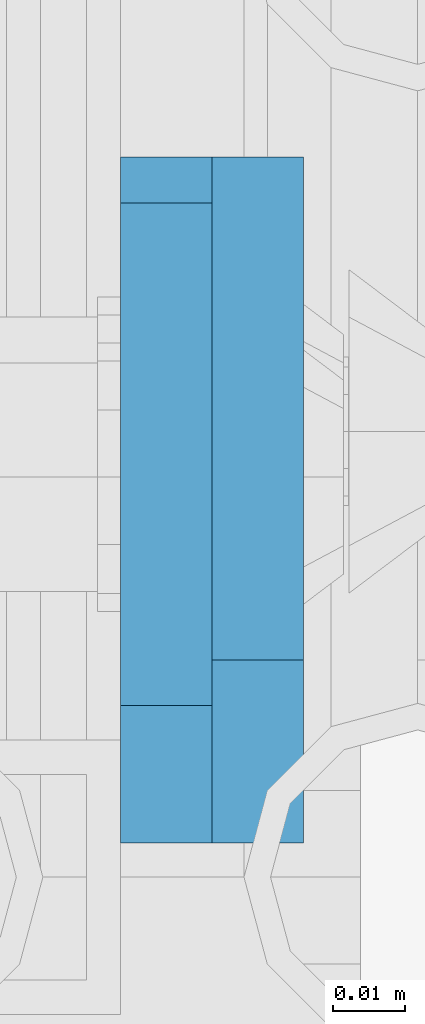
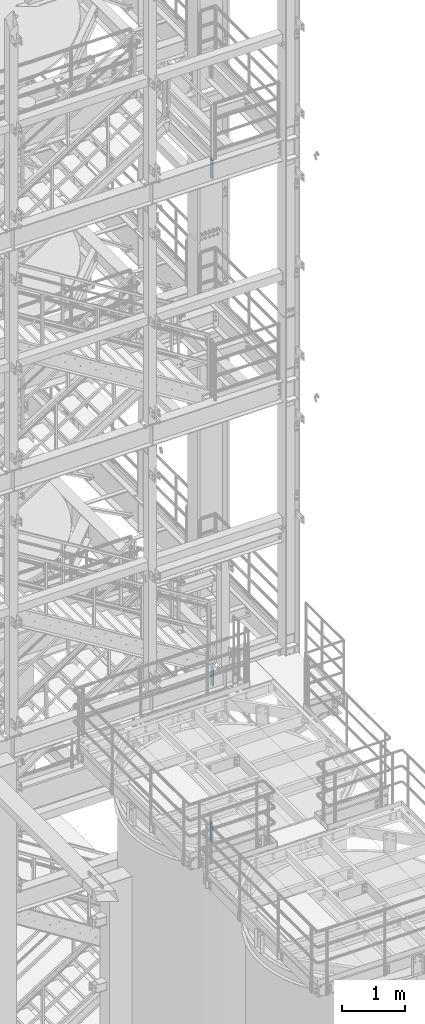
# One storey, part 1453 of 1876: 3 plates, 3 elements without a shape of their own.
"""IFC2X3 building model written with IfcOpenShell, lengths in millimetres."""

from ifc_helpers import new_model, si_unit, frame, origin_with_axes, place, context, subcontext, project, spatial, faceted_brep, material, type_object, element, aggregate, save


model = new_model("IFC2X3")

# Units and contexts
model_context = context("Model", 3, precision=1e-05, world=origin_with_axes())
body_context = subcontext(model_context, "Body", "Model", "MODEL_VIEW")
ifc_project = project(units=[si_unit("LENGTHUNIT", "METRE", prefix="MILLI"), si_unit("AREAUNIT", "SQUARE_METRE"), si_unit("VOLUMEUNIT", "CUBIC_METRE"), si_unit("MASSUNIT", "GRAM", prefix="KILO"), si_unit("TIMEUNIT", "SECOND"), si_unit("PLANEANGLEUNIT", "RADIAN"), si_unit("SOLIDANGLEUNIT", "STERADIAN"), si_unit("THERMODYNAMICTEMPERATUREUNIT", "DEGREE_CELSIUS"), si_unit("LUMINOUSINTENSITYUNIT", "LUMEN")], contexts=[model_context])

# Site, building, storey
site_placement = place(None, origin_with_axes())
site = spatial("IfcSite", under=ifc_project, at=site_placement, CompositionType="ELEMENT")
building_placement = place(site_placement, origin_with_axes())
building = spatial("IfcBuilding", under=site, at=building_placement, Name="Undefined", CompositionType="ELEMENT")
storey_placement = place(building_placement, origin_with_axes())
storey = spatial("IfcBuildingStorey", under=building, at=storey_placement, Name="Undefined", CompositionType="ELEMENT", Elevation=0.0)

# Assembly, plate
assembly_1_placement = place(storey_placement, origin_with_axes())
assembly_1 = element("IfcElementAssembly", 1, at=assembly_1_placement, inside=storey, Name="BEAM", AssemblyPlace="NOTDEFINED", PredefinedType="RIGID_FRAME")
ifc_material = material(Name="STEEL/A36")
plate_type_1 = type_object("IfcPlateType", PredefinedType="NOTDEFINED")
plate_1_placement = place(assembly_1_placement, frame((6238.87499990463, -7107.2375, 17587.9125), z_axis=(0.0, 0.0, 1.0), x_axis=(0.0, 1.0, 0.0)))
plate_1 = element("IfcPlate", 2, at=plate_1_placement, type_object=plate_type_1, material=ifc_material, Name="PLATE", context=body_context, shape_type="Brep", body=[
    faceted_brep([(0.0, -6.35000000000196, 19.0499992370605), (0.0, -6.35000000000036, 361.950000762939), (0.0, 6.35000000000036, 361.950000762939), (0.0, 6.35000000000105, 19.0499992370605), (19.0499992370605, -6.35000000000036, 381.0), (19.0499992370605, 6.35000000000036, 381.0), (88.9000015258789, -6.35000000000036, 381.0), (88.9000015258789, 6.35000000000036, 381.0), (88.9000015258789, -6.34999999999991, 0.0), (88.9000015258789, 6.34999999999991, 0.0), (19.0499992370642, -6.35000000000105, 0.0), (19.0499992370633, 6.35000000000105, 0.0)], [[[0, 1, 2, 3]], [[1, 4, 5, 2]], [[4, 6, 7, 5]], [[6, 8, 9, 7]], [[8, 10, 11, 9]], [[10, 0, 3, 11]], [[5, 7, 9, 11, 3, 2]], [[10, 8, 6, 4, 1, 0]]]),
])
aggregate(assembly_1, [plate_1])

assembly_2_placement = place(storey_placement, origin_with_axes())
assembly_2 = element("IfcElementAssembly", 3, at=assembly_2_placement, inside=storey, Name="BEAM", AssemblyPlace="NOTDEFINED", PredefinedType="RIGID_FRAME")
plate_type_2 = type_object("IfcPlateType", PredefinedType="NOTDEFINED")
plate_2_placement = place(assembly_2_placement, frame((6251.57499990463, -7107.2375, 7759.7), z_axis=(0.0, 0.0, 1.0), x_axis=(0.0, 1.0, 0.0)))
plate_2 = element("IfcPlate", 4, at=plate_2_placement, type_object=plate_type_2, material=ifc_material, Name="PLATE", context=body_context, shape_type="Brep", body=[
    faceted_brep([(0.0, -6.35000000000036, 25.4000000000005), (0.0, -6.35000000000036, 354.012506484985), (0.0, 6.35000000000036, 354.012506484985), (0.0, 6.35000000000036, 25.4000000000005), (25.3999996185303, -6.35000000000036, 379.412506103516), (25.3999996185303, 6.35000000000036, 379.412506103516), (95.25, -6.35000000000036, 379.412506103516), (95.25, 6.35000000000036, 379.412506103516), (95.25, -6.35000000000036, 0.0), (95.25, 6.35000000000036, 0.0), (25.3999996185303, -6.34999999999991, 0.0), (25.3999996185303, 6.34999999999991, 0.0)], [[[0, 1, 2, 3]], [[1, 4, 5, 2]], [[4, 6, 7, 5]], [[6, 8, 9, 7]], [[8, 10, 11, 9]], [[10, 0, 3, 11]], [[5, 7, 9, 11, 3, 2]], [[10, 8, 6, 4, 1, 0]]]),
])
aggregate(assembly_2, [plate_2])

assembly_3_placement = place(storey_placement, origin_with_axes())
assembly_3 = element("IfcElementAssembly", 5, at=assembly_3_placement, inside=storey, Name="BEAM", AssemblyPlace="NOTDEFINED", PredefinedType="RIGID_FRAME")
plate_3_placement = place(assembly_3_placement, frame((6238.875, -7107.2375, 4737.1), z_axis=(0.0, 0.0, 1.0), x_axis=(0.0, 1.0, 0.0)))
plate_3 = element("IfcPlate", 6, at=plate_3_placement, type_object=plate_type_2, material=ifc_material, Name="PLATE", context=body_context, shape_type="Brep", body=[
    faceted_brep([(0.0, -6.35000000000036, 25.4000000000005), (0.0, -6.35000000000036, 354.012506484985), (0.0, 6.35000000000036, 354.012506484985), (0.0, 6.35000000000036, 25.4000000000005), (25.3999996185303, -6.35000000000036, 379.412506103516), (25.3999996185303, 6.35000000000036, 379.412506103516), (95.25, -6.35000000000036, 379.412506103516), (95.25, 6.35000000000036, 379.412506103516), (95.25, -6.35000000000036, 0.0), (95.25, 6.35000000000036, 0.0), (25.3999996185303, -6.34999999999991, 0.0), (25.3999996185303, 6.34999999999991, 0.0)], [[[0, 1, 2, 3]], [[1, 4, 5, 2]], [[4, 6, 7, 5]], [[6, 8, 9, 7]], [[8, 10, 11, 9]], [[10, 0, 3, 11]], [[5, 7, 9, 11, 3, 2]], [[10, 8, 6, 4, 1, 0]]]),
])
aggregate(assembly_3, [plate_3])

save(model, "model.ifc")
